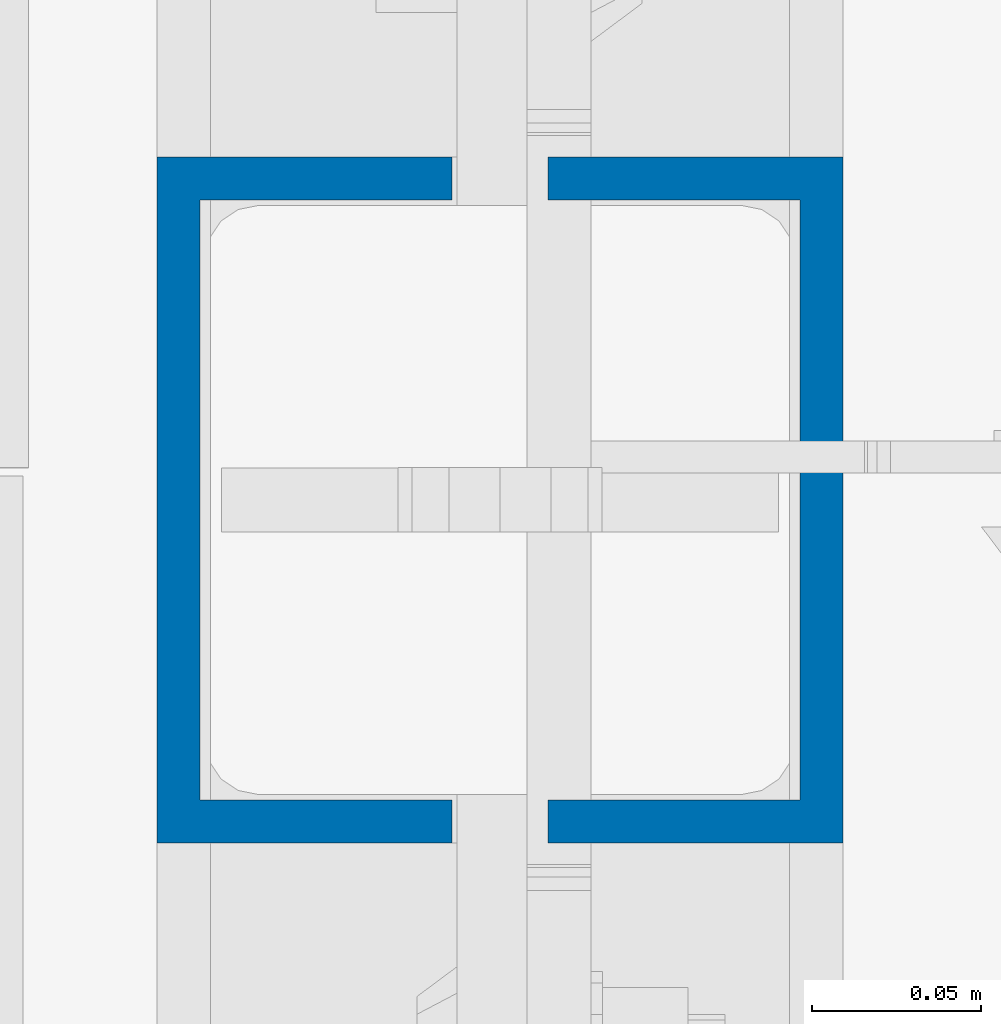
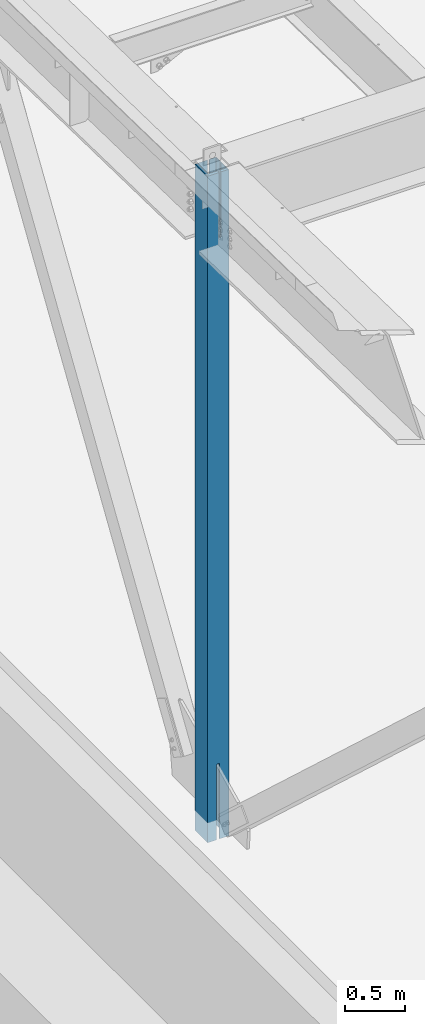
# One storey, part 883 of 1763: 1 column, 1 element without a shape of its own.
"""IFC2X3 building model written with IfcOpenShell, lengths in millimetres."""

from ifc_helpers import new_model, si_unit, frame, origin_with_axes, place, context, subcontext, project, spatial, faceted_brep, material, type_object, element, aggregate, save


model = new_model("IFC2X3")

# Units and contexts
model_context = context("Model", 3, precision=1e-05, world=origin_with_axes())
body_context = subcontext(model_context, "Body", "Model", "MODEL_VIEW")
ifc_project = project(units=[si_unit("LENGTHUNIT", "METRE", prefix="MILLI"), si_unit("AREAUNIT", "SQUARE_METRE"), si_unit("VOLUMEUNIT", "CUBIC_METRE"), si_unit("MASSUNIT", "GRAM", prefix="KILO"), si_unit("TIMEUNIT", "SECOND"), si_unit("PLANEANGLEUNIT", "RADIAN"), si_unit("SOLIDANGLEUNIT", "STERADIAN"), si_unit("THERMODYNAMICTEMPERATUREUNIT", "DEGREE_CELSIUS"), si_unit("LUMINOUSINTENSITYUNIT", "LUMEN")], contexts=[model_context])

# Site, building, storey
site_placement = place(None, origin_with_axes())
site = spatial("IfcSite", under=ifc_project, at=site_placement, CompositionType="ELEMENT")
building_placement = place(site_placement, origin_with_axes())
building = spatial("IfcBuilding", under=site, at=building_placement, Name="Undefined", CompositionType="ELEMENT")
storey_placement = place(building_placement, origin_with_axes())
storey = spatial("IfcBuildingStorey", under=building, at=storey_placement, Name="Undefined", CompositionType="ELEMENT", Elevation=0.0)

# Assembly, column
assembly_placement = place(storey_placement, origin_with_axes())
assembly = element("IfcElementAssembly", 1, at=assembly_placement, inside=storey, Name="COLUMN", AssemblyPlace="NOTDEFINED", PredefinedType="RIGID_FRAME")
ifc_material = material()
column_type = type_object("IfcColumnType", Name="HSS8X8X1/2", PredefinedType="NOTDEFINED")
column_placement = place(assembly_placement, frame((-87375.4372736983, 457.200000000001, 5029.2), z_axis=(0.0, 1.0, 0.0), x_axis=(0.0, 0.0, 1.0)))
column = element("IfcColumn", 2, at=column_placement, type_object=column_type, material=ifc_material, Name="COLUMN", ObjectType="HSS8X8X1/2", context=body_context, shape_type="Brep", body=[
    faceted_brep([(101.600000000009, 14.2875007629336, 101.6), (101.600000000009, 14.2875007629336, 88.8999999999996), (952.079905331025, 14.2875007629627, 88.9), (952.079905331025, 14.2875007629627, 101.6), (956.939984849071, 13.3207708403788, 88.9), (956.939984849071, 13.3207708403788, 101.6), (961.060161317225, 10.5677569398977, 88.9), (961.060161317225, 10.5677569398977, 101.6), (963.813175217703, 6.44758047173673, 88.9), (963.813175217703, 6.44758047173673, 101.6), (964.77990514029, 1.5875009536976, 88.9), (964.77990514029, 1.5875009536976, 101.6), (952.079905331024, -14.2874999999767, 101.6), (952.079905331024, -14.2874999999767, 88.9), (101.600000000009, -14.2875000000058, 88.8999999999996), (101.600000000009, -14.2875000000058, 101.6), (956.939984849069, -13.3207700773928, 101.6), (956.939984849069, -13.3207700773928, 88.9), (961.060161317223, -10.5677561769116, 101.6), (961.060161317223, -10.5677561769116, 88.9), (963.813175217701, -6.44757970876526, 101.6), (963.813175217701, -6.44757970876526, 88.9), (964.77990514029, -1.58750019071158, 101.6), (964.77990514029, -1.58750019071158, 88.9), (858.847235657402, -13.3207700773928, -88.9), (858.847235657402, -13.3207700773928, -101.6), (853.987156139357, -14.2874999999767, -101.6), (853.987156139357, -14.2874999999767, -88.9), (862.967412125556, -10.5677561769116, -88.9), (862.967412125556, -10.5677561769116, -101.6), (865.720426026034, -6.44757970876526, -88.9), (865.720426026034, -6.44757970876526, -101.6), (866.687155948623, -1.58750019071158, -88.9), (866.687155948623, -1.58750019071158, -101.6), (866.687155948623, 1.5875009536976, -88.9), (866.687155948623, 1.5875009536976, -101.6), (865.720426026036, 6.44758047173673, -88.9), (865.720426026036, 6.44758047173673, -101.6), (862.967412125558, 10.5677569398977, -88.9), (862.967412125558, 10.5677569398977, -101.6), (858.847235657404, 13.3207708403788, -88.9), (858.847235657404, 13.3207708403788, -101.6), (853.987156139357, 14.2875007629627, -88.9), (853.987156139357, 14.2875007629627, -101.6), (101.599999999998, 14.2875007629627, -88.9), (101.599999999998, 14.2875007629627, -101.6), (6853.83281709646, 6.34999961852736, 88.9), (6841.13281709646, 6.34999961852736, 101.6), (6841.13281709646, -101.600000000006, 101.6), (6853.83281709646, -88.8999999999942, 88.9), (6192.5941246826, 6.34999961852736, 88.9), (6192.5941246826, 6.34999961852736, 101.6), (6188.34155496745, 7.19588832801674, 88.9), (6188.34155496745, 7.19588832801674, 101.6), (6184.73640044179, 9.60477556845581, 88.9), (6184.73640044179, 9.60477556845581, 101.6), (6182.32751320135, 13.209930094119, 88.9), (6182.32751320135, 13.209930094119, 101.6), (6181.48162449186, 17.4624998092622, 88.9), (6181.48162449186, 17.4624998092622, 101.6), (6182.32751320135, 21.7150695244054, 88.9), (6182.32751320135, 21.7150695244054, 101.6), (6184.73640044179, 25.3202240500686, 88.9), (6184.73640044179, 25.3202240500686, 101.6), (6188.34155496745, 27.7291112905077, 88.9), (6188.34155496745, 27.7291112905077, 101.6), (6192.5941246826, 28.5749999999971, 88.9), (6192.5941246826, 28.5749999999971, 101.6), (6853.83281709646, 28.5749999999971, 88.9), (6841.13281709646, 28.5749999999971, 101.6), (6853.83281709646, 88.8999999999942, 88.9), (6841.13281709646, 101.600000000006, 101.6), (101.599999999999, 88.9000000000015, 88.8999999999996), (101.599999999999, 88.9000000000015, -88.8999999999996), (6853.83281709646, 88.8999999999942, -88.9), (6853.83281709646, 88.8999999999942, 6.35000000002543), (6206.09617139994, 88.8999999999942, 6.35000000002543), (6203.66613164092, 88.8999999999942, 6.83336496131938), (6201.60604340684, 88.8999999999942, 8.20987191155837), (6200.2295364566, 88.8999999999942, 10.2699601456352), (6199.74617149531, 88.8999999999942, 12.699999904658), (6200.2295364566, 88.8999999999942, 15.1300396636808), (6201.60604340684, 88.8999999999942, 17.1901278977576), (6203.66613164092, 88.8999999999942, 18.5666348479966), (6206.09617139994, 88.8999999999942, 19.0499998092906), (6853.83281709646, 88.8999999999942, 19.0499998092906), (6206.09617139994, 101.600000000006, 6.35000000002543), (6841.13281709646, 101.600000000006, 6.35000000002543), (6203.66613164092, 101.600000000006, 6.83336496131938), (6201.60604340684, 101.600000000006, 8.20987191155837), (6200.2295364566, 101.600000000006, 10.2699601456352), (6199.74617149531, 101.600000000006, 12.699999904658), (6200.2295364566, 101.600000000006, 15.1300396636808), (6201.60604340684, 101.600000000006, 17.1901278977576), (6203.66613164092, 101.600000000006, 18.5666348479966), (6206.09617139994, 101.600000000006, 19.0499998092906), (6841.13281709646, 101.600000000006, 19.0499998092906), (6841.13281709646, 101.600000000006, -101.6), (101.599999999999, 101.599999999999, -101.6), (101.599999999999, 101.599999999999, 101.6), (6853.83281709646, 28.5749999999971, -88.9), (6841.13281709646, 28.5749999999971, -101.6), (6192.59414909666, 28.5749999999971, -88.9), (6192.59414909666, 28.5749999999971, -101.6), (6188.34157938151, 27.7291112905077, -88.9), (6188.34157938151, 27.7291112905077, -101.6), (6184.73642485585, 25.3202240500686, -88.9), (6184.73642485585, 25.3202240500686, -101.6), (6182.32753761541, 21.7150695244054, -88.9), (6182.32753761541, 21.7150695244054, -101.6), (6181.48164890592, 17.4624998092622, -88.9), (6181.48164890592, 17.4624998092622, -101.6), (6182.32753761541, 13.209930094119, -88.9), (6182.32753761541, 13.209930094119, -101.6), (6184.73642485585, 9.60477556845581, -88.9), (6184.73642485585, 9.60477556845581, -101.6), (6188.34157938151, 7.19588832801674, -88.9), (6188.34157938151, 7.19588832801674, -101.6), (6192.59414909666, 6.34999961852736, -88.9), (6192.59414909666, 6.34999961852736, -101.6), (101.599999999999, -101.599999999999, -101.6), (101.599999999998, -14.2874999999622, -101.6), (6841.13281709646, 6.34999961852736, -101.6), (6841.13281709646, -101.600000000006, -101.6), (101.599999999998, -14.2874999999622, -88.9), (101.599999999999, -88.9000000000015, -88.8999999999996), (101.599999999999, -88.9000000000015, 88.8999999999996), (6853.83281709646, -88.8999999999942, -88.9), (6853.83281709646, 6.34999961852736, -88.9), (101.599999999999, -101.599999999999, 101.6)], [[[0, 1, 2, 3]], [[3, 2, 4, 5]], [[5, 4, 6, 7]], [[7, 6, 8, 9]], [[9, 8, 10, 11]], [[12, 13, 14, 15]], [[16, 17, 13, 12]], [[18, 19, 17, 16]], [[20, 21, 19, 18]], [[22, 23, 21, 20]], [[11, 10, 23, 22]], [[24, 25, 26, 27]], [[28, 29, 25, 24]], [[30, 31, 29, 28]], [[32, 33, 31, 30]], [[34, 35, 33, 32]], [[36, 37, 35, 34]], [[38, 39, 37, 36]], [[40, 41, 39, 38]], [[42, 43, 41, 40]], [[44, 45, 43, 42]], [[46, 47, 48, 49]], [[50, 51, 47, 46]], [[51, 50, 52, 53]], [[53, 52, 54, 55]], [[55, 54, 56, 57]], [[57, 56, 58, 59]], [[59, 58, 60, 61]], [[61, 60, 62, 63]], [[63, 62, 64, 65]], [[65, 64, 66, 67]], [[67, 66, 68, 69]], [[69, 68, 70, 71]], [[72, 73, 74, 75, 76, 77, 78, 79, 80, 81, 82, 83, 84, 85, 70]], [[86, 76, 75, 87]], [[76, 86, 88, 77]], [[77, 88, 89, 78]], [[78, 89, 90, 79]], [[79, 90, 91, 80]], [[80, 91, 92, 81]], [[81, 92, 93, 82]], [[82, 93, 94, 83]], [[83, 94, 95, 84]], [[84, 95, 96, 85]], [[70, 85, 96, 71]], [[95, 94, 93, 92, 91, 90, 89, 88, 86, 87, 97, 98, 99, 71, 96]], [[75, 74, 97, 87]], [[100, 101, 97, 74]], [[102, 103, 101, 100]], [[104, 105, 103, 102]], [[106, 107, 105, 104]], [[108, 109, 107, 106]], [[110, 111, 109, 108]], [[112, 113, 111, 110]], [[114, 115, 113, 112]], [[116, 117, 115, 114]], [[118, 119, 117, 116]], [[120, 121, 26, 25, 29, 31, 33, 35, 37, 39, 41, 43, 45, 98, 97, 101, 103, 105, 107, 109, 111, 113, 115, 117, 119, 122, 123]], [[27, 26, 121, 124]], [[125, 126, 49, 127]], [[118, 116, 114, 112, 110, 108, 106, 104, 102, 100, 74, 73, 44, 42, 40, 38, 36, 34, 32, 30, 28, 24, 27, 124, 125, 127, 128]], [[119, 118, 128, 122]], [[127, 123, 122, 128]], [[49, 48, 123, 127]], [[129, 120, 123, 48]], [[126, 125, 124, 121, 120, 129, 15, 14]], [[8, 6, 4, 2, 1, 72, 70, 68, 66, 64, 62, 60, 58, 56, 54, 52, 50, 46, 49, 126, 14, 13, 17, 19, 21, 23, 10]], [[99, 98, 45, 44, 73, 72, 1, 0]], [[18, 16, 12, 15, 129, 48, 47, 51, 53, 55, 57, 59, 61, 63, 65, 67, 69, 71, 99, 0, 3, 5, 7, 9, 11, 22, 20]]]),
])
aggregate(assembly, [column])

save(model, "model.ifc")
